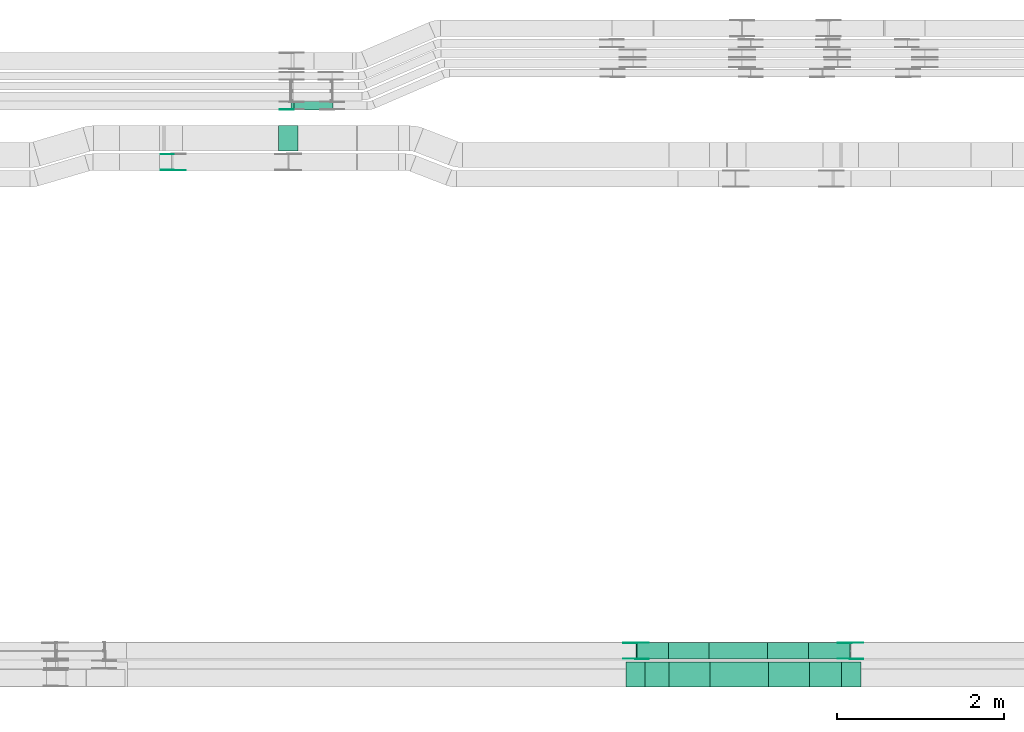
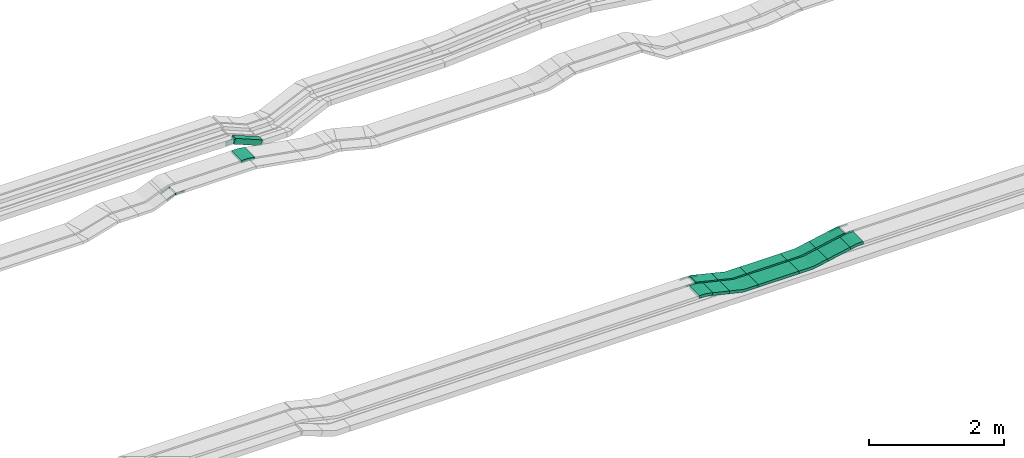
# One storey, part 15 of 31: 19 flow fittings, 7 flow segments.
"""IFC2X3 building model written with IfcOpenShell, lengths in millimetres."""

from ifc_helpers import new_model, entity, si_unit, converted_unit, derived_unit, direction, frame, frame_2d, origin, origin_2d_with_axis, place, context, subcontext, project, spatial, polyline, circle_curve, parameter, trimmed, segment, composite_curve, rectangle, outline, extrude, source, transform, mapped, material, type_object, type_shapes, element, save


model = new_model("IFC2X3")

# Units and contexts
model_context = context("Model", 3, precision=0.01, world=origin(), true_north=direction((6.12303176911189e-17, 1.0)))
body_context = subcontext(model_context, "Body", "Model", "MODEL_VIEW")
ifc_project = project(units=[si_unit("LENGTHUNIT", "METRE", prefix="MILLI"), si_unit("AREAUNIT", "SQUARE_METRE"), si_unit("VOLUMEUNIT", "CUBIC_METRE"), converted_unit("PLANEANGLEUNIT", "DEGREE", entity("IfcRatioMeasure", 0.0174532925199433), si_unit("PLANEANGLEUNIT", "RADIAN"), dimensions=[0, 0, 0, 0, 0, 0, 0]), si_unit("MASSUNIT", "GRAM", prefix="KILO"), derived_unit("MASSDENSITYUNIT", [(si_unit("MASSUNIT", "GRAM", prefix="KILO"), 1), (si_unit("LENGTHUNIT", "METRE"), -3)]), derived_unit("MOMENTOFINERTIAUNIT", [(si_unit("LENGTHUNIT", "METRE"), 4)]), si_unit("TIMEUNIT", "SECOND"), si_unit("FREQUENCYUNIT", "HERTZ"), si_unit("THERMODYNAMICTEMPERATUREUNIT", "DEGREE_CELSIUS"), derived_unit("THERMALTRANSMITTANCEUNIT", [(si_unit("MASSUNIT", "GRAM", prefix="KILO"), 1), (si_unit("THERMODYNAMICTEMPERATUREUNIT", "KELVIN"), -1), (si_unit("TIMEUNIT", "SECOND"), -3)]), derived_unit("VOLUMETRICFLOWRATEUNIT", [(si_unit("LENGTHUNIT", "METRE"), 3), (si_unit("TIMEUNIT", "SECOND"), -1)]), derived_unit("MASSFLOWRATEUNIT", [(si_unit("MASSUNIT", "GRAM", prefix="KILO"), 1), (si_unit("TIMEUNIT", "SECOND"), -1)]), derived_unit("ROTATIONALFREQUENCYUNIT", [(si_unit("TIMEUNIT", "SECOND"), -1)]), si_unit("ELECTRICCURRENTUNIT", "AMPERE"), si_unit("ELECTRICVOLTAGEUNIT", "VOLT"), si_unit("POWERUNIT", "WATT"), si_unit("FORCEUNIT", "NEWTON", prefix="KILO"), si_unit("ILLUMINANCEUNIT", "LUX"), si_unit("LUMINOUSFLUXUNIT", "LUMEN"), si_unit("LUMINOUSINTENSITYUNIT", "CANDELA"), derived_unit("USERDEFINED", [(si_unit("MASSUNIT", "GRAM", prefix="KILO"), -1), (si_unit("LENGTHUNIT", "METRE"), -2), (si_unit("TIMEUNIT", "SECOND"), 3), (si_unit("LUMINOUSFLUXUNIT", "LUMEN"), 1)]), derived_unit("LINEARVELOCITYUNIT", [(si_unit("LENGTHUNIT", "METRE"), 1), (si_unit("TIMEUNIT", "SECOND"), -1)]), si_unit("PRESSUREUNIT", "PASCAL"), derived_unit("USERDEFINED", [(si_unit("LENGTHUNIT", "METRE"), -2), (si_unit("MASSUNIT", "GRAM", prefix="KILO"), 1), (si_unit("TIMEUNIT", "SECOND"), -2)]), derived_unit("LINEARFORCEUNIT", [(si_unit("MASSUNIT", "GRAM", prefix="KILO"), 1), (si_unit("LENGTHUNIT", "METRE"), 1), (si_unit("TIMEUNIT", "SECOND"), -2), (si_unit("LENGTHUNIT", "METRE"), -1)]), derived_unit("PLANARFORCEUNIT", [(si_unit("MASSUNIT", "GRAM", prefix="KILO"), 1), (si_unit("LENGTHUNIT", "METRE"), 1), (si_unit("TIMEUNIT", "SECOND"), -2), (si_unit("LENGTHUNIT", "METRE"), -2)])], contexts=[model_context])

# Site, building, storey
site_placement = place(None, frame((0.0, -0.00077364408347762, 0.0)))
site = spatial("IfcSite", under=ifc_project, at=site_placement, CompositionType="ELEMENT")
building_placement = place(site_placement, origin())
building = spatial("IfcBuilding", under=site, at=building_placement, CompositionType="ELEMENT")
storey_placement = place(building_placement, frame((0.0, 0.0, 15900.0)))
storey = spatial("IfcBuildingStorey", under=building, at=storey_placement, CompositionType="ELEMENT", Elevation=15900.0)

# Flow segments
cable_carrier_segment_type = type_object("IfcCableCarrierSegmentType", PredefinedType="CABLETRAYSEGMENT")
flow_segment_1_placement = place(storey_placement, frame((50193.496338457, 8550.14880665482, 2670.0)))
element("IfcFlowSegment", 1, at=flow_segment_1_placement, inside=storey, type_object=cable_carrier_segment_type, context=body_context, shape_type="SweptSolid", body=[
    extrude(rectangle(XDim=698.184892642371, YDim=200.0, at=origin_2d_with_axis()), frame((349.092446321185, 100.0, 0.0), z_axis=(0.0, 0.0, 1.0), x_axis=(-1.0, 0.0, 0.0)), (0.0, 0.0, 1.0), 50.0000000000016),
])
flow_segment_2_placement = place(storey_placement, frame((50203.178584101, 8215.14880665482, 2670.0)))
element("IfcFlowSegment", 2, at=flow_segment_2_placement, inside=storey, type_object=cable_carrier_segment_type, context=body_context, shape_type="SweptSolid", body=[
    extrude(rectangle(XDim=698.304534220649, YDim=300.000000000001, at=frame_2d((0.0, 1.08002495835535e-12), x_axis=(1.0, 0.0))), frame((349.152267110324, 150.0, 0.0), z_axis=(0.0, 0.0, 1.0), x_axis=(-1.0, 0.0, 0.0)), (0.0, 0.0, 1.0), 50.0000000000016),
])
flow_segment_3_placement = place(storey_placement, frame((49413.9474684942, 8215.14880665482, 2727.47729014539)))
element("IfcFlowSegment", 3, at=flow_segment_3_placement, inside=storey, type_object=cable_carrier_segment_type, context=body_context, shape_type="SweptSolid", body=[
    extrude(rectangle(XDim=50.0000000000005, YDim=296.977603274496, at=frame_2d((4.46220838057343e-12, 7.105427357601e-14), x_axis=(0.0, 1.0))), frame((150.288323737471, 0.0, 58.0415781938621), z_axis=(0.0, 1.0, 0.0), x_axis=(-0.973915582918312, 0.0, 0.226910637363885)), (0.0, 0.0, 1.0), 300.000000000001),
])
flow_segment_4_placement = place(storey_placement, frame((51391.5988838429, 8215.14880665482, 2719.91367915955)))
element("IfcFlowSegment", 4, at=flow_segment_4_placement, inside=storey, type_object=cable_carrier_segment_type, context=body_context, shape_type="SweptSolid", body=[
    extrude(rectangle(XDim=50.0000000000021, YDim=300.000000000001, at=origin_2d_with_axis()), frame((4.9421172393508, 150.0, 24.506641491493), z_axis=(0.980265659659677, 0.0, 0.197684689574023), x_axis=(-0.197684689574023, 0.0, 0.980265659659677)), (0.0, 0.0, 1.0), 395.138063612391),
])
flow_segment_5_placement = place(storey_placement, frame((49317.6067383754, 8550.14880665483, 2729.26975274885)))
element("IfcFlowSegment", 5, at=flow_segment_5_placement, inside=storey, type_object=cable_carrier_segment_type, context=body_context, shape_type="SweptSolid", body=[
    extrude(rectangle(XDim=50.0000000000019, YDim=200.0, at=origin_2d_with_axis()), frame((5.84484575630645, 100.0, 114.692753075124), z_axis=(0.972286194973467, 0.0, -0.233793830252249), x_axis=(0.233793830252249, 0.0, 0.972286194973467)), (0.0, 0.0, 1.0), 386.603864196462),
])
flow_segment_6_placement = place(storey_placement, frame((51381.7969966207, 8550.14880665482, 2719.91367915955)))
element("IfcFlowSegment", 6, at=flow_segment_6_placement, inside=storey, type_object=cable_carrier_segment_type, context=body_context, shape_type="SweptSolid", body=[
    extrude(rectangle(XDim=50.0000000000021, YDim=200.0, at=frame_2d((0.0, 1.08713038571295e-12), x_axis=(1.0, 0.0))), frame((4.9421172393508, 100.0, 24.5066414914951), z_axis=(0.980265659659677, 0.0, 0.197684689574023), x_axis=(-0.197684689574023, 0.0, 0.980265659659677)), (0.0, 0.0, 1.0), 504.893418932324),
])
flow_segment_7_placement = place(storey_placement, frame((45186.7757361808, 15124.9939089947, 2643.11749400891)))
element("IfcFlowSegment", 7, at=flow_segment_7_placement, inside=storey, type_object=cable_carrier_segment_type, context=body_context, shape_type="SweptSolid", body=[
    extrude(rectangle(XDim=99.9999999999964, YDim=99.9999999999989, at=frame_2d((1.00541797110054e-12, 0.0), x_axis=(1.0, 0.0))), frame((18.9845844974888, 50.0, 237.415755358855), z_axis=(0.92511308529448, 0.0, -0.37969168994979), x_axis=(0.37969168994979, 0.0, 0.92511308529448)), (0.0, 0.0, 1.0), 503.461377096309),
])

# Flow fittings
ifc_material_1 = material()
cable_carrier_fitting_type_1 = type_object("IfcCableCarrierFittingType", Name="470_DKC_S5_CS 90 internal vertical angle:-", PredefinedType="NOTDEFINED", material=ifc_material_1)
shared_shape_1 = source(origin(), body_context, "Body", "SweptSolid", [
    extrude(outline(composite_curve([segment(polyline([(-248.691747391449, -40.1192495274484), (-14.3556142569722, -40.1192495274484)]), True, "CONTINUOUS"), segment(trimmed(circle_curve(frame_2d((-14.3556142569725, 124.88075047255), x_axis=(0.0, -1.0)), 164.999999999999), [parameter(0.0)], [parameter(13.115255993311)], True, "PARAMETER"), True, "CONTINUOUS"), segment(polyline([(23.0846409080622, -35.8153207089713), (251.308252608551, 17.3580406179518)]), True, "CONTINUOUS"), segment(polyline([(251.308252608551, 17.3580406179518), (239.962720740359, 66.0538197638681)]), True, "CONTINUOUS"), segment(polyline([(239.962720740359, 66.0538197638681), (11.7391090398697, 12.880458436945)]), True, "CONTINUOUS"), segment(trimmed(circle_curve(frame_2d((-14.3556142569725, 124.88075047255), x_axis=(0.0, -1.0)), 114.999999999999), [parameter(0.0)], [parameter(13.115255993311)], True, "PARAMETER"), False, "CONTINUOUS"), segment(polyline([(-14.3556142569722, 9.88075047255185), (-248.691747391449, 9.88075047255187)]), True, "CONTINUOUS"), segment(polyline([(-248.691747391449, 9.88075047255187), (-248.691747391449, -40.1192495274484)]), True, "CONTINUOUS")], self_intersect=False)), frame((-1.73802698373079, 15.1192495274412, -150.0)), (0.0, 0.0, 1.0), 300.0),
])
type_shapes(cable_carrier_fitting_type_1, [shared_shape_1])
flow_fitting_1_placement = place(storey_placement, frame((49952.7488097258, 8365.14880665483, 2695.0), z_axis=(0.0, 1.0, 0.0), x_axis=(-1.0, 0.0, 0.0)))
element("IfcFlowFitting", 8, at=flow_fitting_1_placement, inside=storey, type_object=cable_carrier_fitting_type_1, material=ifc_material_1, Name="470_DKC_S5_CS 90 internal vertical angle:-", ObjectType="470_DKC_S5_CS 90 internal vertical angle:-", context=body_context, shape_type="MappedRepresentation", body=[
    mapped(shared_shape_1, transform((0.0, 0.0, 0.0), scale=1.0)),
])
cable_carrier_fitting_type_2 = type_object("IfcCableCarrierFittingType", Name="470_DKC_S5_CD 90 external vertical angle:-", PredefinedType="NOTDEFINED", material=ifc_material_1)
shared_shape_2 = source(origin(), body_context, "Body", "SweptSolid", [
    extrude(outline(composite_curve([segment(polyline([(-112.781024123074, -32.5228429645793), (-18.1027204923938, -32.5228429645792)]), True, "CONTINUOUS"), segment(trimmed(circle_curve(frame_2d((-18.1027204923941, 157.47715703542), x_axis=(0.0, -1.0)), 189.999999999999), [parameter(0.0)], [parameter(13.1152559933101)], True, "PARAMETER"), True, "CONTINUOUS"), segment(polyline([(25.0103006067336, -27.5668037190609), (117.218975876926, -6.08328949769713)]), True, "CONTINUOUS"), segment(polyline([(117.218975876926, -6.08328949769711), (105.873444008734, 42.6124896482194)]), True, "CONTINUOUS"), segment(polyline([(105.873444008734, 42.6124896482194), (13.664768738542, 21.1289754268556)]), True, "CONTINUOUS"), segment(trimmed(circle_curve(frame_2d((-18.1027204923941, 157.47715703542), x_axis=(0.0, -1.0)), 139.999999999999), [parameter(0.0)], [parameter(13.1152559933101)], True, "PARAMETER"), False, "CONTINUOUS"), segment(polyline([(-18.1027204923938, 17.477157035421), (-112.781024123074, 17.477157035421)]), True, "CONTINUOUS"), segment(polyline([(-112.781024123074, 17.477157035421), (-112.781024123074, -32.5228429645792)]), True, "CONTINUOUS")], self_intersect=False)), frame((-0.864785255577832, 7.52284296457204, -150.0)), (0.0, 0.0, 1.0), 300.0),
])
type_shapes(cable_carrier_fitting_type_2, [shared_shape_2])
flow_fitting_2_placement = place(storey_placement, frame((49308.938809741, 8365.14880665483, 2845.0), z_axis=(0.0, 1.0, 0.0), x_axis=(1.0, 0.0, 0.0)))
element("IfcFlowFitting", 9, at=flow_fitting_2_placement, inside=storey, type_object=cable_carrier_fitting_type_2, material=ifc_material_1, Name="470_DKC_S5_CD 90 external vertical angle:-", ObjectType="470_DKC_S5_CD 90 external vertical angle:-", context=body_context, shape_type="MappedRepresentation", body=[
    mapped(shared_shape_2, transform((0.0, 0.0, 0.0), scale=1.0)),
])
cable_carrier_fitting_type_3 = type_object("IfcCableCarrierFittingType", Name="470_DKC_S5_CS 90 internal vertical angle:-", PredefinedType="NOTDEFINED", material=ifc_material_1)
shared_shape_3 = source(origin(), body_context, "Body", "SweptSolid", [
    extrude(outline(composite_curve([segment(polyline([(-248.693365447544, -38.0457820746743), (-12.6735042029556, -38.0457820746743)]), True, "CONTINUOUS"), segment(trimmed(circle_curve(frame_2d((-12.6735042029559, 126.954217925325), x_axis=(0.0, -1.0)), 164.999999999999), [parameter(0.0)], [parameter(11.4015985350609)], True, "PARAMETER"), True, "CONTINUOUS"), segment(polyline([(19.9444695767387, -34.7896159185248), (251.306634552456, 11.867897084888)]), True, "CONTINUOUS"), segment(polyline([(251.306634552456, 11.867897084888), (241.422400073761, 60.8811800678733)]), True, "CONTINUOUS"), segment(polyline([(241.422400073761, 60.8811800678733), (10.0602350980433, 14.2236670644605)]), True, "CONTINUOUS"), segment(trimmed(circle_curve(frame_2d((-12.6735042029559, 126.954217925325), x_axis=(0.0, -1.0)), 114.999999999999), [parameter(0.0)], [parameter(11.4015985350609)], True, "PARAMETER"), False, "CONTINUOUS"), segment(polyline([(-12.6735042029556, 11.954217925326), (-248.693365447544, 11.954217925326)]), True, "CONTINUOUS"), segment(polyline([(-248.693365447544, 11.954217925326), (-248.693365447544, -38.0457820746742)]), True, "CONTINUOUS")], self_intersect=False)), frame((-1.30232596171276, 13.045782074667, -150.0)), (0.0, 0.0, 1.0), 300.0),
])
type_shapes(cable_carrier_fitting_type_3, [shared_shape_3])
flow_fitting_3_placement = place(storey_placement, frame((51151.4788097309, 8365.14880665482, 2695.0), z_axis=(0.0, -1.0, 0.0), x_axis=(1.0, 0.0, 0.0)))
element("IfcFlowFitting", 10, at=flow_fitting_3_placement, inside=storey, type_object=cable_carrier_fitting_type_3, material=ifc_material_1, Name="470_DKC_S5_CS 90 internal vertical angle:-", ObjectType="470_DKC_S5_CS 90 internal vertical angle:-", context=body_context, shape_type="MappedRepresentation", body=[
    mapped(shared_shape_3, transform((0.0, 0.0, 0.0), scale=1.0)),
])
cable_carrier_fitting_type_4 = type_object("IfcCableCarrierFittingType", Name="470_DKC_S5_CS 90 internal vertical angle:-", PredefinedType="NOTDEFINED", material=ifc_material_1)
shared_shape_4 = source(origin(), body_context, "Body", "SweptSolid", [
    extrude(outline(composite_curve([segment(polyline([(-248.698515211643, -40.6142100817285), (-14.7446300278562, -40.6142100817285)]), True, "CONTINUOUS"), segment(trimmed(circle_curve(frame_2d((-14.7446300278566, 124.38578991827), x_axis=(0.0, -1.0)), 164.999999999999), [parameter(0.0)], [parameter(13.5205338655362)], True, "PARAMETER"), True, "CONTINUOUS"), segment(polyline([(23.8313519637492, -36.0414322523542), (251.301484788357, 18.6555426671362)]), True, "CONTINUOUS"), segment(polyline([(251.301484788357, 18.6555426671362), (239.611793275749, 67.2698524158109)]), True, "CONTINUOUS"), segment(polyline([(239.61179327575, 67.269852415811), (12.1416604511412, 12.5728774963205)]), True, "CONTINUOUS"), segment(trimmed(circle_curve(frame_2d((-14.7446300278566, 124.38578991827), x_axis=(0.0, -1.0)), 114.999999999999), [parameter(0.0)], [parameter(13.5205338655362)], True, "PARAMETER"), False, "CONTINUOUS"), segment(polyline([(-14.7446300278562, 9.38578991827181), (-248.698515211643, 9.38578991827181)]), True, "CONTINUOUS"), segment(polyline([(-248.698515211643, 9.38578991827181), (-248.698515211643, -40.6142100817284)]), True, "CONTINUOUS")], self_intersect=False)), frame((-1.85090074181679, 15.6142100817211, -100.0)), (0.0, 0.0, 1.0), 200.0),
])
type_shapes(cable_carrier_fitting_type_4, [shared_shape_4])
flow_fitting_4_placement = place(storey_placement, frame((49942.9469225036, 8650.14880665483, 2695.0), z_axis=(0.0, 1.0, 0.0), x_axis=(-1.0, 0.0, 0.0)))
element("IfcFlowFitting", 11, at=flow_fitting_4_placement, inside=storey, type_object=cable_carrier_fitting_type_4, material=ifc_material_1, Name="470_DKC_S5_CS 90 internal vertical angle:-", ObjectType="470_DKC_S5_CS 90 internal vertical angle:-", context=body_context, shape_type="MappedRepresentation", body=[
    mapped(shared_shape_4, transform((0.0, 0.0, 0.0), scale=1.0)),
])
cable_carrier_fitting_type_5 = type_object("IfcCableCarrierFittingType", Name="470_DKC_S5_CS 90 internal vertical angle:-", PredefinedType="NOTDEFINED", material=ifc_material_1)
shared_shape_5 = source(origin(), body_context, "Body", "SweptSolid", [
    extrude(outline(composite_curve([segment(polyline([(-248.693365447544, -38.0457820746743), (-12.6735042029556, -38.0457820746743)]), True, "CONTINUOUS"), segment(trimmed(circle_curve(frame_2d((-12.6735042029559, 126.954217925325), x_axis=(0.0, -1.0)), 164.999999999999), [parameter(0.0)], [parameter(11.4015985350609)], True, "PARAMETER"), True, "CONTINUOUS"), segment(polyline([(19.9444695767387, -34.7896159185248), (251.306634552456, 11.867897084888)]), True, "CONTINUOUS"), segment(polyline([(251.306634552456, 11.867897084888), (241.422400073761, 60.8811800678733)]), True, "CONTINUOUS"), segment(polyline([(241.422400073761, 60.8811800678733), (10.0602350980432, 14.2236670644604)]), True, "CONTINUOUS"), segment(trimmed(circle_curve(frame_2d((-12.6735042029559, 126.954217925325), x_axis=(0.0, -1.0)), 114.999999999999), [parameter(0.0)], [parameter(11.4015985350609)], True, "PARAMETER"), False, "CONTINUOUS"), segment(polyline([(-12.6735042029556, 11.954217925326), (-248.693365447544, 11.954217925326)]), True, "CONTINUOUS"), segment(polyline([(-248.693365447544, 11.954217925326), (-248.693365447544, -38.0457820746743)]), True, "CONTINUOUS")], self_intersect=False)), frame((-1.30232596171274, 13.045782074667, -100.0)), (0.0, 0.0, 1.0), 200.0),
])
type_shapes(cable_carrier_fitting_type_5, [shared_shape_5])
flow_fitting_5_placement = place(storey_placement, frame((51141.6769225087, 8650.14880665482, 2695.0), z_axis=(0.0, -1.0, 0.0), x_axis=(1.0, 0.0, 0.0)))
element("IfcFlowFitting", 12, at=flow_fitting_5_placement, inside=storey, type_object=cable_carrier_fitting_type_5, material=ifc_material_1, Name="470_DKC_S5_CS 90 internal vertical angle:-", ObjectType="470_DKC_S5_CS 90 internal vertical angle:-", context=body_context, shape_type="MappedRepresentation", body=[
    mapped(shared_shape_5, transform((0.0, 0.0, 0.0), scale=1.0)),
])
ifc_material_2 = material(Name="G")
cable_carrier_fitting_type_6 = type_object("IfcCableCarrierFittingType", PredefinedType="NOTDEFINED", material=ifc_material_2)
shared_shape_6 = source(origin(), body_context, "Body", "SweptSolid", [
    extrude(outline(composite_curve([segment(trimmed(circle_curve(frame_2d((-44.5901162790698, 0.0), x_axis=(1.0, 0.0)), 12.5), [parameter(90.0000000000007)], [parameter(270.0)], True, "PARAMETER"), True, "CONTINUOUS"), segment(polyline([(-44.5901162790697, -12.5), (-33.0901162790698, -12.5)]), True, "CONTINUOUS"), segment(polyline([(-33.0901162790698, -12.5), (-31.2296511627907, -14.5)]), True, "CONTINUOUS"), segment(polyline([(-31.2296511627907, -14.5), (108.90988372093, -14.5)]), True, "CONTINUOUS"), segment(polyline([(108.90988372093, -14.5), (108.90988372093, 14.5)]), True, "CONTINUOUS"), segment(polyline([(108.90988372093, 14.5), (-31.2296511627907, 14.5)]), True, "CONTINUOUS"), segment(polyline([(-31.2296511627907, 14.5), (-33.0901162790698, 12.5)]), True, "CONTINUOUS"), segment(polyline([(-33.0901162790698, 12.5), (-44.5901162790699, 12.5)]), True, "CONTINUOUS")], self_intersect=False)), frame((44.5901162790698, 0.0, 0.0), z_axis=(0.0, 0.0, -1.0), x_axis=(1.0, 0.0, 0.0)), (0.0, 0.0, -1.0), 2.0),
])
type_shapes(cable_carrier_fitting_type_6, [shared_shape_6])
for number, where, z_axis, x_axis in (
    (13, (49319.1369225188, 8745.60880666499, 2845.0), (0.0, 1.0, 0.0), (0.972286194973484, 0.0, -0.233793830252179)),
    (14, (51885.4869224935, 8745.60880666498, 2845.0), (0.0, 1.0, 0.0), (1.0, 0.0, 0.0)),
):
    element("IfcFlowFitting", number, at=place(storey_placement, frame(where, z_axis=z_axis, x_axis=x_axis)), inside=storey, type_object=cable_carrier_fitting_type_6, material=ifc_material_2, context=body_context, shape_type="MappedRepresentation", body=[
        mapped(shared_shape_6, transform((0.0, 0.0, 0.0), scale=1.0)),
    ])
cable_carrier_fitting_type_7 = type_object("IfcCableCarrierFittingType", PredefinedType="NOTDEFINED", material=ifc_material_2)
shared_shape_7 = source(origin(), body_context, "Body", "SweptSolid", [
    extrude(outline(composite_curve([segment(trimmed(circle_curve(frame_2d((-44.5901162790697, 0.0), x_axis=(1.0, 0.0)), 12.5), [parameter(90.0000000000007)], [parameter(270.0)], True, "PARAMETER"), True, "CONTINUOUS"), segment(polyline([(-44.5901162790697, -12.5), (-33.0901162790697, -12.5)]), True, "CONTINUOUS"), segment(polyline([(-33.0901162790697, -12.5), (-31.2296511627907, -14.5)]), True, "CONTINUOUS"), segment(polyline([(-31.2296511627907, -14.5), (108.90988372093, -14.5)]), True, "CONTINUOUS"), segment(polyline([(108.90988372093, -14.5), (108.90988372093, 14.5)]), True, "CONTINUOUS"), segment(polyline([(108.90988372093, 14.5), (-31.2296511627907, 14.5)]), True, "CONTINUOUS"), segment(polyline([(-31.2296511627907, 14.5), (-33.0901162790698, 12.5)]), True, "CONTINUOUS"), segment(polyline([(-33.0901162790698, 12.5), (-44.5901162790699, 12.5)]), True, "CONTINUOUS")], self_intersect=False)), frame((44.5901162790697, 0.0, 0.0)), (0.0, 0.0, 1.0), 2.0),
])
type_shapes(cable_carrier_fitting_type_7, [shared_shape_7])
for number, where, z_axis, x_axis in (
    (15, (49319.1369225188, 8554.68880664467, 2845.0), (0.0, -1.0, 0.0), (0.972286194973484, 0.0, -0.233793830252179)),
    (16, (51885.4869224935, 8554.68880664466, 2845.0), (0.0, -1.0, 0.0), (1.0, 0.0, 0.0)),
    (17, (43775.14058495, 14404.5655085037, 2860.0), (0.0, -1.0, 0.0), (1.0, 0.0, 0.0)),
):
    element("IfcFlowFitting", number, at=place(storey_placement, frame(where, z_axis=z_axis, x_axis=x_axis)), inside=storey, type_object=cable_carrier_fitting_type_7, material=ifc_material_2, context=body_context, shape_type="MappedRepresentation", body=[
        mapped(shared_shape_7, transform((0.0, 0.0, 0.0), scale=1.0)),
    ])
cable_carrier_fitting_type_8 = type_object("IfcCableCarrierFittingType", PredefinedType="NOTDEFINED", material=ifc_material_2)
shared_shape_8 = source(origin(), body_context, "Body", "SweptSolid", [
    extrude(outline(composite_curve([segment(trimmed(circle_curve(frame_2d((-44.5901162790698, 0.0), x_axis=(1.0, 0.0)), 12.5), [parameter(90.0000000000007)], [parameter(270.0)], True, "PARAMETER"), True, "CONTINUOUS"), segment(polyline([(-44.5901162790697, -12.5), (-33.0901162790698, -12.5)]), True, "CONTINUOUS"), segment(polyline([(-33.0901162790698, -12.5), (-31.2296511627907, -14.5)]), True, "CONTINUOUS"), segment(polyline([(-31.2296511627907, -14.5), (108.90988372093, -14.5)]), True, "CONTINUOUS"), segment(polyline([(108.90988372093, -14.5), (108.90988372093, 14.5)]), True, "CONTINUOUS"), segment(polyline([(108.90988372093, 14.5), (-31.2296511627907, 14.5)]), True, "CONTINUOUS"), segment(polyline([(-31.2296511627907, 14.5), (-33.0901162790698, 12.5)]), True, "CONTINUOUS"), segment(polyline([(-33.0901162790698, 12.5), (-44.5901162790699, 12.5)]), True, "CONTINUOUS")], self_intersect=False)), frame((44.5901162790698, 0.0, 0.0), z_axis=(0.0, 0.0, -1.0), x_axis=(1.0, 0.0, 0.0)), (0.0, 0.0, -1.0), 2.0),
])
type_shapes(cable_carrier_fitting_type_8, [shared_shape_8])
for number, where, z_axis, x_axis in (
    (18, (49319.1369225189, 8556.68880664467, 2845.0), (0.0, -1.0, 0.0), (-1.0, 0.0, 0.0)),
    (19, (51885.4869224935, 8556.68880664466, 2845.0), (0.0, -1.0, 0.0), (-0.980265659659694, 0.0, -0.197684689573939)),
    (20, (43775.14058495, 14406.5655085037, 2860.0), (0.0, -1.0, 0.0), (-0.923879532511193, 0.0, -0.382683432365316)),
):
    element("IfcFlowFitting", number, at=place(storey_placement, frame(where, z_axis=z_axis, x_axis=x_axis)), inside=storey, type_object=cable_carrier_fitting_type_8, material=ifc_material_2, context=body_context, shape_type="MappedRepresentation", body=[
        mapped(shared_shape_8, transform((0.0, 0.0, 0.0), scale=1.0)),
    ])
cable_carrier_fitting_type_9 = type_object("IfcCableCarrierFittingType", PredefinedType="NOTDEFINED", material=ifc_material_2)
shared_shape_9 = source(origin(), body_context, "Body", "SweptSolid", [
    extrude(outline(composite_curve([segment(trimmed(circle_curve(frame_2d((-44.5901162790697, 0.0), x_axis=(1.0, 0.0)), 12.5), [parameter(90.0000000000007)], [parameter(270.0)], True, "PARAMETER"), True, "CONTINUOUS"), segment(polyline([(-44.5901162790697, -12.5), (-33.0901162790697, -12.5)]), True, "CONTINUOUS"), segment(polyline([(-33.0901162790697, -12.5), (-31.2296511627907, -14.5)]), True, "CONTINUOUS"), segment(polyline([(-31.2296511627907, -14.5), (108.90988372093, -14.5)]), True, "CONTINUOUS"), segment(polyline([(108.90988372093, -14.5), (108.90988372093, 14.5)]), True, "CONTINUOUS"), segment(polyline([(108.90988372093, 14.5), (-31.2296511627907, 14.5)]), True, "CONTINUOUS"), segment(polyline([(-31.2296511627907, 14.5), (-33.0901162790698, 12.5)]), True, "CONTINUOUS"), segment(polyline([(-33.0901162790698, 12.5), (-44.5901162790699, 12.5)]), True, "CONTINUOUS")], self_intersect=False)), frame((44.5901162790697, 0.0, 0.0)), (0.0, 0.0, 1.0), 2.0),
])
type_shapes(cable_carrier_fitting_type_9, [shared_shape_9])
for number, where, z_axis, x_axis in (
    (21, (49319.1369225189, 8743.60880666498, 2845.0), (0.0, 1.0, 0.0), (-1.0, 0.0, 0.0)),
    (22, (51885.4869224935, 8743.60880666498, 2845.0), (0.0, 1.0, 0.0), (-0.980265659659694, 0.0, -0.197684689573939)),
    (23, (43775.14058495, 14593.4855085241, 2860.0), (0.0, 1.0, 0.0), (-0.923879532511193, 0.0, -0.382683432365316)),
):
    element("IfcFlowFitting", number, at=place(storey_placement, frame(where, z_axis=z_axis, x_axis=x_axis)), inside=storey, type_object=cable_carrier_fitting_type_9, material=ifc_material_2, context=body_context, shape_type="MappedRepresentation", body=[
        mapped(shared_shape_9, transform((0.0, 0.0, 0.0), scale=1.0)),
    ])
cable_carrier_fitting_type_10 = type_object("IfcCableCarrierFittingType", Name="470_DKC_S5_CD 90 external vertical angle:-", PredefinedType="NOTDEFINED", material=ifc_material_1)
shared_shape_10 = source(origin(), body_context, "Body", "SweptSolid", [
    extrude(outline(composite_curve([segment(polyline([(-113.008381429236, -31.4307750152608), (-15.8295468409386, -31.4307750152608)]), True, "CONTINUOUS"), segment(trimmed(circle_curve(frame_2d((-15.8295468409388, 158.569224984738), x_axis=(0.0, -1.0)), 189.999999999999), [parameter(0.0)], [parameter(11.4015985350617)], True, "PARAMETER"), True, "CONTINUOUS"), segment(polyline([(21.7305441781063, -27.6812503506033), (116.991618570764, -8.47048260186035)]), True, "CONTINUOUS"), segment(polyline([(116.991618570764, -8.47048260186037), (107.107384092068, 40.5428003811248)]), True, "CONTINUOUS"), segment(polyline([(107.107384092068, 40.5428003811248), (11.8463096994101, 21.3320326323818)]), True, "CONTINUOUS"), segment(trimmed(circle_curve(frame_2d((-15.8295468409388, 158.569224984738), x_axis=(0.0, -1.0)), 139.999999999999), [parameter(0.0)], [parameter(11.4015985350617)], True, "PARAMETER"), False, "CONTINUOUS"), segment(polyline([(-15.8295468409386, 18.5692249847395), (-113.008381429236, 18.5692249847395)]), True, "CONTINUOUS"), segment(polyline([(-113.008381429236, 18.5692249847395), (-113.008381429236, -31.4307750152608)]), True, "CONTINUOUS")], self_intersect=False)), frame((-0.641967281709235, 6.43077501525355, -150.0)), (0.0, 0.0, 1.0), 300.0),
])
type_shapes(cable_carrier_fitting_type_10, [shared_shape_10])
flow_fitting_6_placement = place(storey_placement, frame((51895.2888097157, 8365.14880665482, 2845.0), z_axis=(0.0, 1.0, 0.0), x_axis=(0.980265659659693, 0.0, 0.197684689573945)))
element("IfcFlowFitting", 24, at=flow_fitting_6_placement, inside=storey, type_object=cable_carrier_fitting_type_10, material=ifc_material_1, Name="470_DKC_S5_CD 90 external vertical angle:-", ObjectType="470_DKC_S5_CD 90 external vertical angle:-", context=body_context, shape_type="MappedRepresentation", body=[
    mapped(shared_shape_10, transform((0.0, 0.0, 0.0), scale=1.0)),
])
cable_carrier_fitting_type_11 = type_object("IfcCableCarrierFittingType", PredefinedType="NOTDEFINED", material=ifc_material_2)
shared_shape_11 = source(origin(), body_context, "Body", "SweptSolid", [
    extrude(outline(composite_curve([segment(trimmed(circle_curve(frame_2d((-41.4651162790697, 0.0), x_axis=(1.0, 0.0)), 25.0), [parameter(90.0000000000007)], [parameter(270.0)], True, "PARAMETER"), True, "CONTINUOUS"), segment(polyline([(-41.4651162790697, -25.0), (-29.9651162790697, -25.0)]), True, "CONTINUOUS"), segment(polyline([(-29.9651162790697, -25.0), (-28.1046511627907, -38.5)]), True, "CONTINUOUS"), segment(polyline([(-28.1046511627907, -38.5), (99.5348837209303, -38.5)]), True, "CONTINUOUS"), segment(polyline([(99.5348837209303, -38.5), (99.5348837209303, 38.5)]), True, "CONTINUOUS"), segment(polyline([(99.5348837209303, 38.5), (-28.1046511627907, 38.5)]), True, "CONTINUOUS"), segment(polyline([(-28.1046511627907, 38.5), (-29.9651162790697, 25.0)]), True, "CONTINUOUS"), segment(polyline([(-29.9651162790697, 25.0), (-41.46511627907, 25.0)]), True, "CONTINUOUS")], self_intersect=False)), frame((41.4651162790697, 0.0, 0.0), z_axis=(0.0, 0.0, -1.0), x_axis=(1.0, 0.0, 0.0)), (0.0, 0.0, -1.0), 2.0),
])
type_shapes(cable_carrier_fitting_type_11, [shared_shape_11])
flow_fitting_7_placement = place(storey_placement, frame((45194.98232223, 15129.5339089845, 2884.95683445177), z_axis=(0.0, -1.0, 0.0), x_axis=(-1.0, 0.0, 0.0)))
element("IfcFlowFitting", 25, at=flow_fitting_7_placement, inside=storey, type_object=cable_carrier_fitting_type_11, material=ifc_material_2, context=body_context, shape_type="MappedRepresentation", body=[
    mapped(shared_shape_11, transform((0.0, 0.0, 0.0), scale=1.0)),
])
cable_carrier_fitting_type_12 = type_object("IfcCableCarrierFittingType", Name="470_DKC_S5_CD 90 external vertical angle:-", PredefinedType="NOTDEFINED", material=ifc_material_1)
shared_shape_12 = source(origin(), body_context, "Body", "SweptSolid", [
    extrude(outline(composite_curve([segment(polyline([(-113.234735444067, -30.4436671332716), (-13.6867534803244, -30.4436671332716)]), True, "CONTINUOUS"), segment(trimmed(circle_curve(frame_2d((-13.6867534803247, 159.556332866727), x_axis=(0.0, -1.0)), 189.999999999999), [parameter(0.0)], [parameter(9.80566826552648)], True, "PARAMETER"), True, "CONTINUOUS"), segment(polyline([(18.6715736001671, -27.6679675553907), (116.765264555933, -10.7142509207293)]), True, "CONTINUOUS"), segment(polyline([(116.765264555933, -10.7142509207293), (108.249915324224, 38.5553018219339)]), True, "CONTINUOUS"), segment(polyline([(108.249915324224, 38.5553018219339), (10.1562243684586, 21.6015851872725)]), True, "CONTINUOUS"), segment(trimmed(circle_curve(frame_2d((-13.6867534803247, 159.556332866727), x_axis=(0.0, -1.0)), 139.999999999999), [parameter(0.0)], [parameter(9.80566826552648)], True, "PARAMETER"), False, "CONTINUOUS"), segment(polyline([(-13.6867534803244, 19.5563328667287), (-113.234735444067, 19.5563328667286)]), True, "CONTINUOUS"), segment(polyline([(-113.234735444067, 19.5563328667286), (-113.234735444067, -30.4436671332716)]), True, "CONTINUOUS")], self_intersect=False)), frame((-0.466958150403467, 5.44366713326441, -150.0)), (0.0, 0.0, 1.0), 300.0),
])
type_shapes(cable_carrier_fitting_type_12, [shared_shape_12])
flow_fitting_8_placement = place(storey_placement, frame((45155.14058495, 14785.0255085139, 2860.0), z_axis=(0.0, 1.0, 0.0), x_axis=(1.0, 0.0, 0.0)))
element("IfcFlowFitting", 26, at=flow_fitting_8_placement, inside=storey, type_object=cable_carrier_fitting_type_12, material=ifc_material_1, Name="470_DKC_S5_CD 90 external vertical angle:-", ObjectType="470_DKC_S5_CD 90 external vertical angle:-", context=body_context, shape_type="MappedRepresentation", body=[
    mapped(shared_shape_12, transform((0.0, 0.0, 0.0), scale=1.0)),
])

save(model, "model.ifc")
